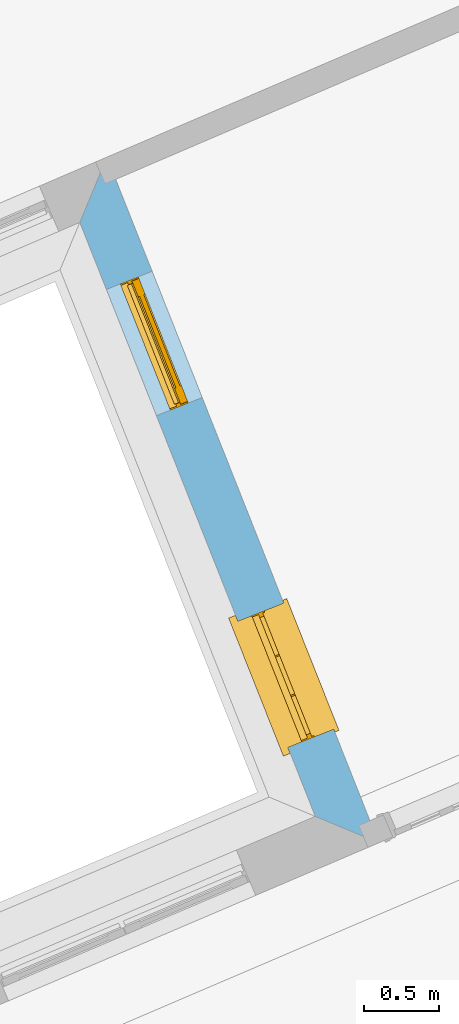
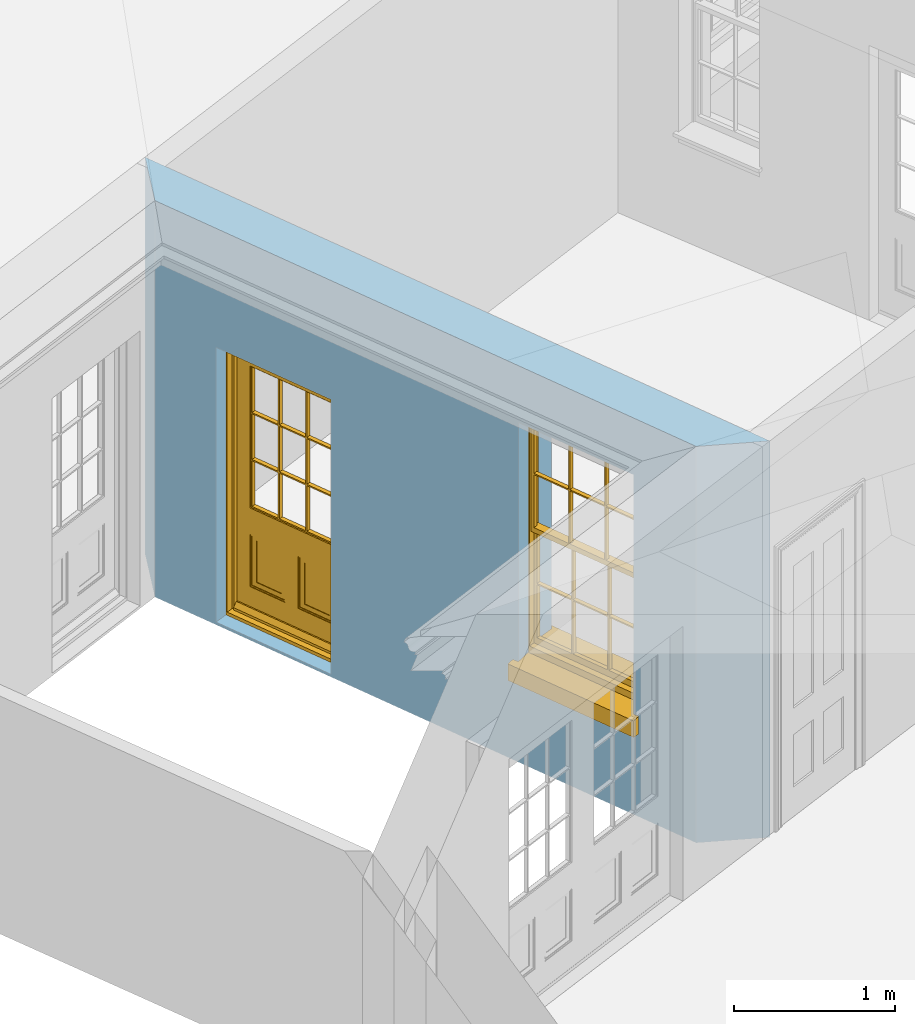
# One storey, part 7 of 19: 1 door, 1 window, 2 openings, plus 1 element that does not belong to this part.
"""IFC2X3 building model written with IfcOpenShell, lengths in metres."""

from ifc_helpers import new_model, si_unit, frame, origin, place, context, subcontext, project, spatial, polyline, outline, extrude, faceted_brep, material, layer, layer_set, layer_usage, element, fill, save


model = new_model("IFC2X3")

# Units and contexts
model_context = context("Model", 3, world=origin())
body_context = subcontext(model_context, "Body", "Model", "MODEL_VIEW")
ifc_project = project(units=[si_unit("PLANEANGLEUNIT", "RADIAN"), si_unit("MASSUNIT", "GRAM", prefix="KILO"), si_unit("FORCEUNIT", "NEWTON", prefix="KILO"), si_unit("LENGTHUNIT", "METRE")], contexts=[model_context])

# Site, building, storey
site_placement = place(None, origin())
site = spatial("IfcSite", under=ifc_project, at=site_placement, CompositionType="ELEMENT")
building_placement = place(None, origin())
building = spatial("IfcBuilding", under=site, at=building_placement, Name="Building plot-0", CompositionType="ELEMENT")
storey_placement = place(None, origin())
storey = spatial("IfcBuildingStorey", under=building, at=storey_placement, Name="Floor 0", CompositionType="ELEMENT", Elevation=0.0)

# Wall, openings, door, window
ifc_material = material(Name="Masonry")
ifc_layer = layer(ifc_material, 0.33, ventilated=False)
ifc_layer_set = layer_set([ifc_layer], Name="My Wall")
ifc_layer_usage = layer_usage(ifc_layer_set, "AXIS2", "NEGATIVE", 0.08)
wall_placement = place(storey_placement, origin())
wall = element("IfcWallStandardCase", 1, at=wall_placement, inside=storey, material=ifc_layer_usage, Name="exterior", context=body_context, shape_type="SweptSolid", body=[
    extrude(outline(polyline([(15.9635555189143, 31.1783080951337), (15.7818582558488, 30.741179576684), (17.3592391354437, 26.7621166784652), (17.784510830655, 26.584810219007), (15.9635555189143, 31.1783080951337)])), origin(), (0.0, 0.0, 1.0), 3.0),
])
opening_1_placement = place(storey_placement, frame((0.0, 0.0, 0.02)))
opening_1 = element("IfcOpeningElement", 2, at=opening_1_placement, cuts=wall, Name="Opening", ObjectType="Opening", context=body_context, shape_type="SweptSolid", body=[
    extrude(outline(polyline([(15.9599028628528, 30.2920485525146), (16.2952561162138, 29.446094537535), (16.6020306491185, 29.5677061568856), (16.2666773957576, 30.4136601718653), (15.9599028628528, 30.2920485525146)])), origin(), (0.0, 0.0, 1.0), 2.08),
])
opening_2_placement = place(storey_placement, frame((0.0, 0.0, 0.75)))
opening_2 = element("IfcOpeningElement", 3, at=opening_2_placement, cuts=wall, Name="Opening", ObjectType="Opening", context=body_context, shape_type="SweptSolid", body=[
    extrude(outline(polyline([(16.8408563451297, 28.0697765814704), (17.1762095984907, 27.2238225664908), (17.4829841313954, 27.3454341858414), (17.1476308780345, 28.1913882008211), (16.8408563451297, 28.0697765814704)])), origin(), (0.0, 0.0, 1.0), 1.82),
])
door_placement = place(storey_placement, frame((16.1923078120231, 30.3841785671742, 0.02), z_axis=(0.0, 0.0, 1.0), x_axis=(0.335353253360928, -0.845954014979682, 0.0)))
door = element("IfcDoor", 4, at=door_placement, inside=storey, Name="circulation outside door", OverallHeight=2.08, OverallWidth=0.91, context=body_context, shape_type="Brep", held_by="IfcProductRepresentation", body=[
    faceted_brep([(0.545, -0.055, 0.265), (0.745, -0.055, 0.265), (0.745, -0.05, 0.265), (0.545, -0.05, 0.265), (0.745, -0.05, 0.58), (0.545, -0.05, 0.58), (0.545, -0.055, 0.58), (0.515, -0.06, 0.235), (0.775, -0.06, 0.235), (0.745, -0.055, 0.58), (0.515, -0.06, 0.61), (0.515, -0.065, 0.235), (0.775, -0.065, 0.235), (0.775, -0.06, 0.61), (0.515, -0.065, 0.61), (0.785, -0.065, 0.225), (0.505, -0.065, 0.225), (0.775, -0.065, 0.61), (0.505, -0.065, 0.62), (0.785, -0.065, 0.62), (0.505, -0.07, 0.225), (0.785, -0.07, 0.225), (0.505, -0.07, 0.62), (0.785, -0.07, 0.62), (0.883, -0.07, 0.075), (0.898, -0.07, 0.075), (0.405, -0.07, 0.62), (0.405, -0.07, 0.225), (0.027, -0.07, 0.075), (0.785, -0.07, 0.82), (0.125, -0.07, 0.82), (0.405, -0.065, 0.62), (0.405, -0.065, 0.225), (0.898, -0.07, 2.068), (0.027, -0.08, 0.075), (0.883, -0.08, 0.075), (0.125, -0.07, 0.225), (0.012, -0.07, 0.075), (0.785, -0.06, 0.82), (0.125, -0.06, 0.82), (0.125, -0.07, 0.62), (0.125, -0.065, 0.62), (0.395, -0.065, 0.61), (0.395, -0.065, 0.235), (0.125, -0.065, 0.225), (0.785, -0.07, 1.895), (0.027, -0.11, 0.045), (0.883, -0.11, 0.045), (0.558333, -0.06, 0.83), (0.351667, -0.06, 0.83), (0.125, -0.07, 1.895), (0.125, -0.06, 1.895), (0.785, -0.06, 1.895), (0.012, -0.07, 2.068), (0.135, -0.065, 0.61), (0.395, -0.06, 0.61), (0.395, -0.06, 0.235), (0.135, -0.065, 0.235), (0.027, -0.11, 0.027), (0.883, -0.11, 0.027), (0.568333, -0.06, 0.83), (0.558333, -0.03, 0.83), (0.351667, -0.03, 0.83), (0.341667, -0.06, 0.83), (0.135, -0.06, 1.185), (0.135, -0.06, 1.53), (0.775, -0.06, 1.53), (0.775, -0.06, 1.185), (0.135, -0.06, 0.61), (0.365, -0.055, 0.58), (0.365, -0.055, 0.265), (0.135, -0.06, 0.235), (0.568333, -0.06, 1.175), (0.558333, -0.06, 1.175), (0.775, -0.06, 0.83), (0.558333, -0.03, 1.175), (0.785, -0.03, 0.82), (0.125, -0.03, 0.82), (0.351667, -0.03, 1.175), (0.351667, -0.06, 1.175), (0.341667, -0.06, 1.175), (0.135, -0.06, 0.83), (0.135, -0.06, 1.175), (0.135, -0.03, 1.185), (0.135, -0.03, 1.53), (0.135, -0.06, 1.54), (0.351667, -0.06, 1.885), (0.558333, -0.06, 1.885), (0.775, -0.03, 1.53), (0.775, -0.03, 1.185), (0.775, -0.06, 1.175), (0.775, -0.06, 1.54), (0.165, -0.055, 0.58), (0.365, -0.05, 0.58), (0.365, -0.05, 0.265), (0.165, -0.055, 0.265), (0.568333, -0.03, 0.83), (0.568333, -0.03, 1.175), (0.568333, -0.06, 1.185), (0.558333, -0.06, 1.185), (0.775, -0.03, 0.83), (0.785, -0.02, 0.82), (0.125, -0.02, 0.82), (0.341667, -0.03, 0.83), (0.341667, -0.03, 1.175), (0.351667, -0.06, 1.185), (0.341667, -0.06, 1.185), (0.135, -0.03, 0.83), (0.341667, -0.03, 1.185), (0.125, -0.03, 1.895), (0.341667, -0.03, 1.53), (0.341667, -0.06, 1.53), (0.135, -0.06, 1.885), (0.341667, -0.06, 1.54), (0.341667, -0.06, 1.885), (0.558333, -0.03, 1.885), (0.351667, -0.03, 1.885), (0.568333, -0.06, 1.885), (0.785, -0.03, 1.895), (0.568333, -0.03, 1.185), (0.568333, -0.06, 1.53), (0.568333, -0.03, 1.53), (0.568333, -0.06, 1.54), (0.775, -0.06, 1.885), (0.165, -0.05, 0.58), (0.165, -0.05, 0.265), (0.775, -0.03, 1.175), (0.558333, -0.06, 1.53), (0.351667, -0.03, 1.185), (0.558333, -0.03, 1.185), (0.505, -0.02, 0.62), (0.405, -0.02, 0.62), (0.125, -0.02, 1.895), (0.785, -0.02, 1.895), (0.351667, -0.06, 1.53), (0.135, -0.03, 1.175), (0.135, -0.03, 1.54), (0.341667, -0.03, 1.54), (0.135, -0.03, 1.885), (0.351667, -0.06, 1.54), (0.558333, -0.03, 1.54), (0.558333, -0.06, 1.54), (0.351667, -0.03, 1.54), (0.775, -0.03, 1.54), (0.568333, -0.03, 1.54), (0.775, -0.03, 1.885), (0.558333, -0.03, 1.53), (0.405, -0.02, 0.225), (0.505, -0.02, 0.225), (0.125, -0.02, 0.62), (0.785, -0.02, 0.62), (0.012, -0.02, 2.068), (0.898, -0.02, 2.068), (0.351667, -0.03, 1.53), (0.341667, -0.03, 1.885), (0.568333, -0.03, 1.885), (0.405, -0.025, 0.225), (0.405, -0.025, 0.62), (0.505, -0.025, 0.62), (0.505, -0.025, 0.225), (0.898, -0.02, 0.027), (0.012, -0.02, 0.027), (0.125, -0.025, 0.62), (0.785, -0.025, 0.62), (0.395, -0.025, 0.235), (0.395, -0.025, 0.61), (0.125, -0.02, 0.225), (0.125, -0.025, 0.225), (0.515, -0.025, 0.61), (0.515, -0.025, 0.235), (0.785, -0.02, 0.225), (0.785, -0.025, 0.225), (0.135, -0.025, 0.61), (0.775, -0.025, 0.61), (0.135, -0.025, 0.235), (0.395, -0.03, 0.235), (0.395, -0.03, 0.61), (0.515, -0.03, 0.61), (0.515, -0.03, 0.235), (0.775, -0.025, 0.235), (0.135, -0.03, 0.61), (0.775, -0.03, 0.61), (0.135, -0.03, 0.235), (0.365, -0.035, 0.265), (0.365, -0.035, 0.58), (0.545, -0.035, 0.58), (0.545, -0.035, 0.265), (0.775, -0.03, 0.235), (0.165, -0.035, 0.58), (0.745, -0.035, 0.58), (0.165, -0.035, 0.265), (0.365, -0.04, 0.58), (0.365, -0.04, 0.265), (0.545, -0.04, 0.58), (0.545, -0.04, 0.265), (0.745, -0.035, 0.265), (0.165, -0.04, 0.58), (0.745, -0.04, 0.58), (0.165, -0.04, 0.265), (0.745, -0.04, 0.265), (0.885, -0.072, 0.025), (0.025, -0.072, 0.025), (0.025, -0.1, 0.025), (0.885, -0.1, 0.025), (0.9, -0.02, 0.025), (0.01, -0.02, 0.025), (0.9, -0.072, 0.025), (0.91, -0.02, 0.0), (0.0, -0.02, 0.0), (0.01, -0.072, 0.025), (0.9, -0.072, 2.07), (0.9, -0.02, 2.07), (0.885, -0.072, 2.055), (0.91, -0.02, 2.08), (0.01, -0.02, 2.07), (0.0, -0.02, 2.08), (0.01, -0.072, 2.07), (0.025, -0.072, 2.055), (0.0, -0.15, 2.08), (0.91, -0.15, 2.08), (0.01, -0.15, 2.07), (0.9, -0.15, 2.07), (0.01, -0.1, 2.07), (0.9, -0.1, 2.07), (0.0, -0.15, 0.0), (0.91, -0.15, 0.0), (0.01, -0.15, 0.025), (0.9, -0.15, 0.025), (0.01, -0.1, 0.025), (0.025, -0.1, 2.055), (0.9, -0.1, 0.025), (0.885, -0.1, 2.055), (0.898, -0.07, 0.027), (0.012, -0.07, 0.027), (0.883, -0.07, 0.027), (0.027, -0.07, 0.027)], [[[0, 1, 2, 3]], [[2, 4, 5, 3]], [[0, 3, 5, 6]], [[1, 0, 7, 8]], [[9, 4, 2, 1]], [[9, 6, 5, 4]], [[0, 6, 10, 7]], [[8, 7, 11, 12]], [[8, 13, 9, 1]], [[13, 10, 6, 9]], [[7, 10, 14, 11]], [[15, 12, 11, 16]], [[12, 17, 13, 8]], [[17, 14, 10, 13]], [[18, 16, 11, 14]], [[15, 19, 17, 12]], [[15, 16, 20, 21]], [[14, 17, 19, 18]], [[16, 18, 22, 20]], [[21, 23, 19, 15]], [[24, 25, 21, 20]], [[23, 22, 18, 19]], [[20, 22, 26, 27]], [[23, 21, 25]], [[28, 24, 20, 27]], [[22, 23, 29]], [[29, 30, 26, 22]], [[27, 26, 31, 32]], [[23, 25, 33, 29]], [[34, 35, 24, 28]], [[28, 27, 36, 37]], [[38, 39, 30, 29]], [[26, 30, 40]], [[26, 40, 41, 31]], [[42, 43, 32, 31]], [[32, 44, 36, 27]], [[33, 45, 29]], [[46, 47, 35, 34]], [[36, 40, 37]], [[39, 38, 48, 49]], [[50, 30, 39, 51]], [[29, 45, 52, 38]], [[53, 37, 40, 30]], [[44, 41, 40, 36]], [[31, 41, 54, 42]], [[43, 42, 55, 56]], [[57, 44, 32, 43]], [[50, 45, 33, 53]], [[47, 46, 58, 59]], [[60, 48, 38]], [[49, 48, 61, 62]], [[49, 63, 39]], [[50, 53, 30]], [[51, 39, 64, 65]], [[45, 50, 51, 52]], [[66, 67, 38, 52]], [[57, 54, 41, 44]], [[42, 54, 68, 55]], [[56, 55, 69, 70]], [[56, 71, 57, 43]], [[60, 72, 73, 48]], [[60, 38, 74]], [[48, 73, 75, 61]], [[76, 77, 62, 61]], [[62, 78, 79, 49]], [[49, 79, 80, 63]], [[63, 81, 39]], [[82, 64, 39]], [[65, 64, 83, 84]], [[85, 51, 65]], [[52, 51, 86, 87]], [[88, 89, 67, 66]], [[90, 38, 67]], [[91, 66, 52]], [[71, 68, 54, 57]], [[55, 68, 92, 69]], [[69, 93, 94, 70]], [[70, 95, 71, 56]], [[96, 97, 72, 60]], [[73, 72, 98, 99]], [[74, 38, 90]], [[100, 96, 60, 74]], [[75, 73, 79, 78]], [[61, 75, 97, 96]], [[101, 102, 77, 76]], [[77, 103, 62]], [[96, 76, 61]], [[103, 104, 78, 62]], [[80, 79, 105, 106]], [[63, 80, 104, 103]], [[81, 63, 103, 107]], [[81, 82, 39]], [[106, 64, 82, 80]], [[106, 108, 83, 64]], [[84, 83, 77, 109]], [[110, 111, 65, 84]], [[112, 51, 85]], [[113, 85, 65, 111]], [[114, 86, 51]], [[115, 87, 86, 116]], [[117, 52, 87]], [[118, 76, 89, 88]], [[119, 98, 67, 89]], [[120, 121, 88, 66]], [[67, 98, 72, 90]], [[91, 122, 120, 66]], [[91, 52, 123]], [[95, 92, 68, 71]], [[69, 92, 124, 93]], [[94, 93, 124, 125]], [[94, 125, 95, 70]], [[72, 97, 126, 90]], [[127, 99, 98, 120]], [[99, 105, 79, 73]], [[74, 90, 126, 100]], [[96, 100, 76]], [[128, 129, 75, 78]], [[97, 75, 129, 119]], [[130, 131, 102, 101]], [[109, 77, 102, 132]], [[133, 101, 76, 118]], [[77, 107, 103]], [[78, 104, 108, 128]], [[111, 106, 105, 134]], [[104, 80, 82, 135]], [[107, 135, 82, 81]], [[110, 108, 106, 111]], [[104, 135, 83, 108]], [[83, 135, 77]], [[136, 84, 109]], [[110, 84, 136, 137]], [[114, 51, 112]], [[85, 136, 138, 112]], [[113, 137, 136, 85]], [[111, 134, 139, 113]], [[86, 114, 113, 139]], [[140, 141, 87, 115]], [[139, 142, 116, 86]], [[109, 118, 115, 116]], [[117, 123, 52]], [[117, 87, 141, 122]], [[126, 89, 76]], [[143, 118, 88]], [[120, 98, 119, 121]], [[119, 89, 126, 97]], [[144, 143, 88, 121]], [[144, 122, 91, 143]], [[127, 120, 122, 141]], [[143, 91, 123, 145]], [[124, 92, 95, 125]], [[146, 129, 99, 127]], [[99, 129, 128, 105]], [[100, 126, 76]], [[121, 119, 129, 146]], [[147, 131, 130, 148]], [[131, 149, 102]], [[130, 101, 150]], [[102, 151, 132]], [[118, 109, 132, 133]], [[101, 133, 152]], [[107, 77, 135]], [[153, 128, 108, 110]], [[134, 105, 128, 153]], [[109, 138, 136]], [[153, 110, 137, 142]], [[154, 114, 112, 138]], [[137, 113, 114, 154]], [[141, 139, 134, 127]], [[141, 140, 142, 139]], [[144, 140, 115, 155]], [[142, 137, 154, 116]], [[155, 115, 118]], [[116, 154, 109]], [[117, 155, 145, 123]], [[122, 144, 155, 117]], [[143, 145, 118]], [[121, 146, 140, 144]], [[146, 127, 134, 153]], [[156, 157, 131, 147]], [[148, 130, 158, 159]], [[148, 160, 161, 147]], [[157, 162, 149, 131]], [[161, 151, 102, 149]], [[101, 152, 160, 150]], [[163, 158, 130, 150]], [[151, 152, 133, 132]], [[154, 138, 109]], [[142, 140, 146, 153]], [[145, 155, 118]], [[157, 156, 164, 165]], [[147, 166, 167, 156]], [[168, 169, 159, 158]], [[170, 148, 159, 171]], [[148, 170, 160]], [[166, 147, 161]], [[172, 162, 157, 165]], [[166, 149, 162, 167]], [[166, 161, 149]], [[150, 160, 170]], [[163, 173, 168, 158]], [[171, 163, 150, 170]], [[174, 164, 156, 167]], [[175, 176, 165, 164]], [[169, 168, 177, 178]], [[171, 159, 169, 179]], [[167, 162, 172, 174]], [[176, 180, 172, 165]], [[179, 173, 163, 171]], [[181, 177, 168, 173]], [[164, 174, 182, 175]], [[183, 184, 176, 175]], [[178, 177, 185, 186]], [[179, 169, 178, 187]], [[174, 172, 180, 182]], [[184, 188, 180, 176]], [[187, 181, 173, 179]], [[189, 185, 177, 181]], [[175, 182, 190, 183]], [[191, 184, 183, 192]], [[185, 193, 194, 186]], [[187, 178, 186, 195]], [[182, 180, 188, 190]], [[191, 196, 188, 184]], [[195, 189, 181, 187]], [[197, 193, 185, 189]], [[183, 190, 198, 192]], [[198, 196, 191, 192]], [[194, 193, 197, 199]], [[195, 186, 194, 199]], [[188, 196, 198, 190]], [[197, 189, 195, 199]], [[200, 201, 202, 203]], [[201, 200, 204, 205]], [[206, 204, 200]], [[204, 207, 208, 205]], [[209, 201, 205]], [[210, 211, 204, 206]], [[206, 200, 212, 210]], [[211, 213, 207, 204]], [[214, 205, 208, 215]], [[216, 217, 201, 209]], [[205, 214, 216, 209]], [[216, 214, 211, 210]], [[210, 212, 217, 216]], [[214, 215, 213, 211]], [[218, 219, 213, 215]], [[219, 218, 220, 221]], [[221, 220, 222, 223]], [[215, 208, 224, 218]], [[225, 224, 208, 207]], [[224, 226, 220, 218]], [[224, 225, 227, 226]], [[219, 225, 207, 213]], [[228, 222, 220, 226]], [[219, 221, 227, 225]], [[226, 227, 203, 202]], [[202, 229, 222, 228]], [[228, 226, 202]], [[227, 221, 223, 230]], [[230, 203, 227]], [[217, 229, 202, 201]], [[231, 223, 222, 229]], [[230, 223, 231, 203]], [[231, 229, 217, 212]], [[212, 200, 203, 231]], [[33, 152, 151, 53]], [[25, 160, 152, 33]], [[161, 37, 53, 151]], [[232, 160, 25]], [[161, 233, 37]], [[160, 232, 234]], [[24, 234, 232, 25]], [[233, 161, 235]], [[37, 233, 235, 28]], [[161, 160, 234, 235]], [[35, 47, 234, 24]], [[28, 235, 46, 34]], [[58, 235, 234, 59]], [[59, 234, 47]], [[58, 46, 235]]]),
])
fill(opening_1, door)
window_placement = place(storey_placement, frame((17.0732612943, 28.16190659613, 0.75), z_axis=(0.0, 0.0, 1.0), x_axis=(0.335353253360928, -0.845954014979682, 0.0)))
window = element("IfcWindow", 5, at=window_placement, inside=storey, Name="circulation outside window", OverallHeight=1.82, OverallWidth=0.91, context=body_context, shape_type="Brep", held_by="IfcProductRepresentation", body=[
    faceted_brep([(0.033125, -0.105, 0.975209), (0.01, -0.105, 0.975209), (0.033125, -0.105, 1.376042), (0.876875, -0.105, 0.975209), (0.876875, -0.105, 1.376042), (0.9, -0.105, 0.975209), (0.876875, -0.105, 1.386042), (0.876875, -0.105, 1.786875), (0.9, -0.105, 1.81), (0.033125, -0.105, 1.786875), (0.033125, -0.105, 1.386042), (0.01, -0.105, 1.81), (0.876875, -0.135, 1.376042), (0.876875, -0.135, 0.975209), (0.9, -0.135, 0.937083), (0.033125, -0.135, 1.786875), (0.01, -0.135, 1.81), (0.033125, -0.135, 1.386042), (0.01, -0.135, 0.937083), (0.033125, -0.135, 0.975209), (0.033125, -0.135, 1.376042), (0.876875, -0.135, 1.786875), (0.876875, -0.135, 1.386042), (0.9, -0.135, 1.81), (0.033125, -0.105, 0.937083), (0.01, -0.105, 0.937083), (0.033125, -0.105, 0.53625), (0.876875, -0.105, 0.937083), (0.876875, -0.105, 0.53625), (0.9, -0.105, 0.937083), (0.876875, -0.105, 0.52625), (0.876875, -0.105, 0.125417), (0.9, -0.105, 0.077167), (0.033125, -0.105, 0.125417), (0.033125, -0.105, 0.52625), (0.01, -0.105, 0.077167), (-0.0425, -0.25, 0.01), (-0.0425, -0.3, 0.001667), (0.0, -0.25, 0.01), (0.9525, -0.25, 0.01), (0.91, -0.25, 0.01), (0.9525, -0.3, 0.001667), (-0.02, 0.08, 0.077167), (0.0, 0.08, 0.077167), (-0.02, 0.11, 0.077167), (0.0, -0.06, 0.077167), (0.01, -0.06, 0.077167), (0.91, -0.06, 0.077167), (0.91, 0.08, 0.077167), (0.9, -0.06, 0.077167), (0.93, 0.08, 0.077167), (0.93, 0.11, 0.077167), (0.01, -0.075, 0.975209), (0.9, -0.075, 0.975209), (0.876875, -0.075, 0.125417), (0.876875, -0.075, 0.52625), (0.9, -0.075, 0.077167), (0.876875, -0.075, 0.53625), (0.876875, -0.075, 0.937083), (0.033125, -0.075, 0.125417), (0.01, -0.075, 0.077167), (0.033125, -0.075, 0.52625), (0.033125, -0.075, 0.937083), (0.033125, -0.075, 0.53625), (-0.02, 0.08, 0.052167), (-0.02, 0.11, 0.052167), (0.93, 0.11, 0.052167), (0.93, 0.08, 0.052167), (0.91, 0.08, 0.052167), (0.0, 0.08, 0.052167), (0.91, -0.15, 0.026667), (0.0, -0.15, 0.026667), (-0.0425, -0.3, -0.123333), (0.9525, -0.3, -0.123333), (-0.0425, -0.25, -0.123333), (0.9525, -0.25, -0.123333), (0.01, -0.06, 1.81), (0.9, -0.06, 1.81), (0.0, -0.06, 1.82), (0.91, -0.06, 1.82), (0.01, -0.15, 0.077167), (0.9, -0.15, 0.077167), (0.592292, -0.105, 0.125417), (0.592292, -0.075, 0.125417), (0.317708, -0.075, 0.125417), (0.317708, -0.105, 0.125417), (0.592292, -0.105, 0.53625), (0.317708, -0.105, 0.53625), (0.317708, -0.105, 0.52625), (0.592292, -0.105, 0.52625), (0.592292, -0.075, 0.53625), (0.317708, -0.075, 0.53625), (0.592292, -0.135, 1.386042), (0.592292, -0.105, 1.386042), (0.317708, -0.105, 1.386042), (0.317708, -0.135, 1.386042), (0.317708, -0.135, 1.376042), (0.592292, -0.135, 1.376042), (0.317708, -0.105, 1.376042), (0.592292, -0.105, 1.376042), (0.602292, -0.135, 1.376042), (0.592292, -0.135, 0.975209), (0.602292, -0.135, 0.975209), (0.602292, -0.105, 0.975209), (0.592292, -0.105, 0.975209), (0.602292, -0.105, 1.376042), (0.602292, -0.075, 0.53625), (0.602292, -0.105, 0.53625), (0.317708, -0.075, 0.52625), (0.307708, -0.075, 0.125417), (0.307708, -0.075, 0.52625), (0.602292, -0.075, 0.52625), (0.602292, -0.075, 0.125417), (0.592292, -0.075, 0.52625), (0.307708, -0.075, 0.53625), (0.317708, -0.075, 0.937083), (0.307708, -0.075, 0.937083), (0.602292, -0.075, 0.937083), (0.592292, -0.075, 0.937083), (0.307708, -0.105, 0.52625), (0.307708, -0.105, 0.125417), (0.307708, -0.105, 0.53625), (0.307708, -0.105, 0.937083), (0.592292, -0.105, 0.937083), (0.317708, -0.105, 0.937083), (0.602292, -0.105, 0.937083), (0.602292, -0.105, 0.52625), (0.602292, -0.105, 0.125417), (0.307708, -0.135, 1.386042), (0.307708, -0.135, 1.376042), (0.307708, -0.135, 0.975209), (0.317708, -0.135, 0.975209), (0.317708, -0.135, 1.786875), (0.307708, -0.135, 1.786875), (0.602292, -0.135, 1.786875), (0.592292, -0.135, 1.786875), (0.602292, -0.135, 1.386042), (0.602292, -0.105, 1.386042), (0.307708, -0.105, 1.386042), (0.307708, -0.105, 1.786875), (0.317708, -0.105, 1.786875), (0.592292, -0.105, 1.786875), (0.602292, -0.105, 1.786875), (0.307708, -0.105, 1.376042), (0.317708, -0.105, 0.975209), (0.307708, -0.105, 0.975209), (0.91, -0.15, 1.82), (0.9, -0.15, 1.81), (0.01, -0.15, 1.81), (0.0, -0.15, 1.82), (0.91, -0.25, 0.0), (0.0, -0.25, 0.0), (0.91, 0.08, 0.0), (0.0, 0.08, 0.0)], [[[0, 1, 2]], [[3, 4, 5]], [[6, 7, 8]], [[9, 10, 11]], [[12, 13, 14]], [[15, 16, 17]], [[18, 19, 20]], [[21, 22, 23]], [[24, 25, 26]], [[27, 28, 29]], [[30, 31, 32]], [[33, 34, 35]], [[14, 27, 29]], [[25, 24, 18]], [[36, 37, 38]], [[39, 40, 41]], [[42, 43, 44]], [[45, 46, 43]], [[47, 48, 49]], [[50, 51, 48]], [[1, 0, 52]], [[5, 53, 3]], [[54, 55, 56]], [[57, 58, 53]], [[59, 60, 61]], [[62, 63, 52]], [[48, 43, 46, 49]], [[51, 44, 43, 48]], [[64, 42, 44, 65]], [[65, 44, 51, 66]], [[66, 51, 50, 67]], [[65, 66, 68, 69]], [[60, 56, 49, 46]], [[70, 71, 38, 40]], [[37, 41, 40, 38]], [[37, 72, 73, 41]], [[74, 75, 73, 72]], [[8, 11, 76, 77]], [[76, 78, 79, 77]], [[32, 35, 80, 81]], [[81, 80, 71, 70]], [[82, 83, 84, 85]], [[86, 87, 88, 89]], [[86, 90, 91, 87]], [[92, 93, 94, 95]], [[92, 95, 96, 97]], [[96, 98, 99, 97]], [[100, 97, 101, 102]], [[103, 104, 99, 105]], [[97, 99, 104, 101]], [[102, 103, 105, 100]], [[28, 57, 106, 107]], [[108, 84, 109, 110]], [[111, 112, 83, 113]], [[114, 110, 61, 63]], [[90, 113, 108, 91]], [[115, 91, 114, 116]], [[117, 106, 90, 118]], [[111, 106, 57, 55]], [[119, 110, 109, 120]], [[34, 61, 110, 119]], [[89, 113, 83, 82]], [[88, 108, 113, 89]], [[85, 84, 108, 88]], [[121, 114, 63, 26]], [[122, 116, 114, 121]], [[123, 118, 90, 86]], [[87, 91, 115, 124]], [[107, 106, 117, 125]], [[126, 111, 55, 30]], [[127, 112, 111, 126]], [[126, 30, 28, 107]], [[88, 119, 120, 85]], [[126, 89, 82, 127]], [[125, 123, 86, 107]], [[121, 26, 34, 119]], [[124, 122, 121, 87]], [[128, 17, 20, 129]], [[96, 129, 130, 131]], [[132, 133, 128, 95]], [[134, 135, 92, 136]], [[100, 12, 22, 136]], [[137, 6, 4, 105]], [[94, 138, 139, 140]], [[137, 93, 141, 142]], [[99, 98, 94, 93]], [[143, 2, 10, 138]], [[144, 145, 143, 98]], [[129, 143, 145, 130]], [[20, 2, 143, 129]], [[131, 144, 98, 96]], [[128, 138, 10, 17]], [[133, 139, 138, 128]], [[135, 141, 93, 92]], [[95, 94, 140, 132]], [[22, 6, 137, 136]], [[136, 137, 142, 134]], [[100, 105, 4, 12]], [[107, 86, 89, 126]], [[106, 111, 113, 90]], [[91, 108, 110, 114]], [[87, 121, 119, 88]], [[97, 100, 136, 92]], [[129, 96, 95, 128]], [[98, 143, 138, 94]], [[105, 99, 93, 137]], [[131, 101, 104, 144]], [[124, 115, 118, 123]], [[132, 140, 141, 135]], [[120, 109, 59, 33]], [[15, 9, 139, 133]], [[134, 142, 7, 21]], [[31, 54, 112, 127]], [[36, 74, 72, 37]], [[39, 41, 73, 75]], [[18, 14, 101, 131]], [[23, 16, 132, 135]], [[83, 56, 60, 84]], [[52, 53, 118, 115]], [[53, 52, 144, 104]], [[11, 8, 141, 140]], [[14, 18, 124, 123]], [[2, 1, 11, 10]], [[8, 5, 4, 6]], [[57, 53, 56, 55]], [[60, 52, 63, 61]], [[26, 25, 35, 34]], [[32, 29, 28, 30]], [[14, 23, 22, 12]], [[18, 20, 17, 16]], [[19, 0, 2, 20]], [[17, 10, 9, 15]], [[12, 4, 3, 13]], [[21, 7, 6, 22]], [[27, 58, 57, 28]], [[30, 55, 54, 31]], [[33, 59, 61, 34]], [[26, 63, 62, 24]], [[5, 8, 77, 53]], [[76, 11, 1, 52]], [[46, 45, 78, 76]], [[49, 77, 79, 47]], [[70, 146, 147, 81]], [[71, 80, 148, 149]], [[19, 130, 145, 0]], [[102, 13, 3, 103]], [[116, 122, 24, 62]], [[29, 32, 81, 14]], [[80, 35, 25, 18]], [[60, 46, 76, 52]], [[77, 49, 56, 53]], [[23, 14, 81, 147]], [[16, 148, 80, 18]], [[35, 85, 120]], [[120, 33, 35]], [[127, 82, 32]], [[32, 31, 127]], [[32, 82, 85, 35]], [[102, 101, 14]], [[14, 13, 102]], [[18, 131, 130]], [[130, 19, 18]], [[134, 21, 23]], [[23, 135, 134]], [[16, 15, 133]], [[133, 132, 16]], [[11, 140, 139]], [[139, 9, 11]], [[142, 141, 8]], [[8, 7, 142]], [[23, 147, 148, 16]], [[146, 149, 148, 147]], [[52, 115, 116]], [[116, 62, 52]], [[118, 53, 117]], [[58, 117, 53]], [[27, 125, 117, 58]], [[56, 83, 112]], [[112, 54, 56]], [[109, 84, 60]], [[60, 59, 109]], [[125, 27, 14]], [[14, 123, 125]], [[122, 124, 18]], [[18, 24, 122]], [[145, 144, 52]], [[52, 0, 145]], [[103, 3, 53]], [[53, 104, 103]], [[79, 78, 149, 146]], [[78, 45, 71, 149]], [[146, 70, 47, 79]], [[150, 75, 74, 151]], [[68, 66, 67]], [[48, 68, 67, 50]], [[69, 64, 65]], [[42, 64, 69, 43]], [[69, 68, 152, 153]], [[70, 68, 48, 47]], [[150, 152, 68, 70]], [[43, 69, 71, 45]], [[69, 153, 151, 71]], [[152, 150, 151, 153]], [[38, 151, 74, 36]], [[71, 151, 38]], [[39, 75, 150, 40]], [[40, 150, 70]]]),
])
fill(opening_2, window)

save(model, "model.ifc")
